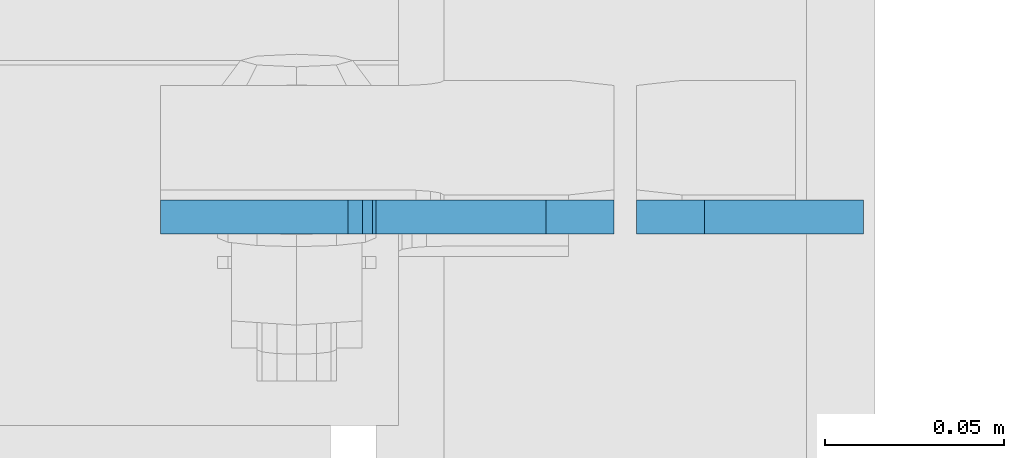
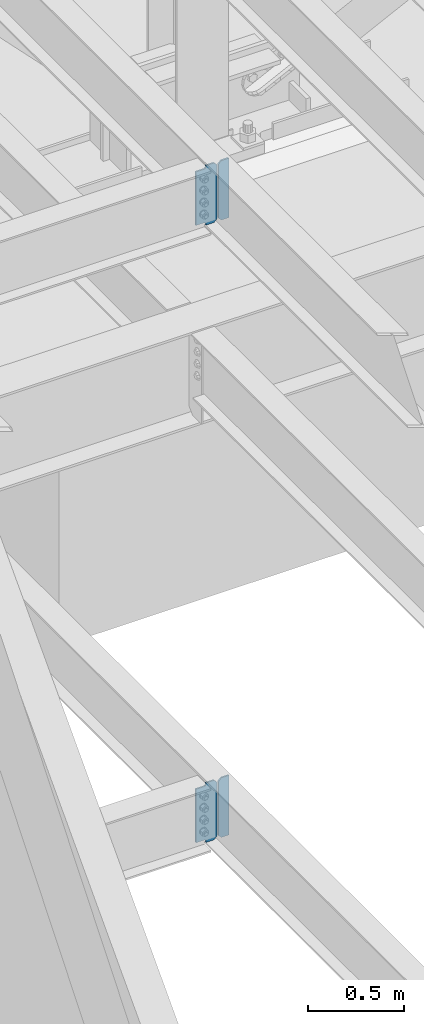
# One storey, part 1026 of 1179: 4 plates, 2 elements without a shape of their own.
"""IFC2X3 building model written with IfcOpenShell, lengths in millimetres."""

from ifc_helpers import new_model, si_unit, frame, origin_with_axes, place, context, subcontext, project, spatial, faceted_brep, material, type_object, element, aggregate, save


model = new_model("IFC2X3")

# Units and contexts
model_context = context("Model", 3, precision=1e-05, world=origin_with_axes())
body_context = subcontext(model_context, "Body", "Model", "MODEL_VIEW")
ifc_project = project(units=[si_unit("LENGTHUNIT", "METRE", prefix="MILLI"), si_unit("AREAUNIT", "SQUARE_METRE"), si_unit("VOLUMEUNIT", "CUBIC_METRE"), si_unit("MASSUNIT", "GRAM", prefix="KILO"), si_unit("TIMEUNIT", "SECOND"), si_unit("PLANEANGLEUNIT", "RADIAN"), si_unit("SOLIDANGLEUNIT", "STERADIAN"), si_unit("THERMODYNAMICTEMPERATUREUNIT", "DEGREE_CELSIUS"), si_unit("LUMINOUSINTENSITYUNIT", "LUMEN")], contexts=[model_context])

# Site, building, storey
site_placement = place(None, origin_with_axes())
site = spatial("IfcSite", under=ifc_project, at=site_placement, CompositionType="ELEMENT")
building_placement = place(site_placement, origin_with_axes())
building = spatial("IfcBuilding", under=site, at=building_placement, Name="Undefined", CompositionType="ELEMENT")
storey_placement = place(building_placement, origin_with_axes())
storey = spatial("IfcBuildingStorey", under=building, at=storey_placement, Name="Undefined", CompositionType="ELEMENT", Elevation=0.0)

# Assembly, plate
assembly_1_placement = place(storey_placement, origin_with_axes())
assembly_1 = element("IfcElementAssembly", 1, at=assembly_1_placement, inside=storey, Name="BEAM", AssemblyPlace="NOTDEFINED", PredefinedType="RIGID_FRAME")
ifc_material = material(Name="STEEL/A36")
plate_type_1 = type_object("IfcPlateType", PredefinedType="NOTDEFINED")
plate_1_placement = place(assembly_1_placement, frame((2409.825, 30729.2379999161, 7623.175), z_axis=(0.0, 0.0, 1.0), x_axis=(-1.0, 0.0, 0.0)))
plate_1 = element("IfcPlate", 2, at=plate_1_placement, type_object=plate_type_1, material=ifc_material, Name="PLATE", context=body_context, shape_type="Brep", body=[
    faceted_brep([(66.6749997905281, -4.76249999999709, 0.0), (66.6749997905281, 4.76249999999709, 0.0), (66.6750000714383, 4.76250000000073, 6.3500003080926), (66.6750000714383, -4.76250000000073, 6.3500003080926), (67.6417300265421, 4.76250000000073, 11.2100797903313), (67.6417300265421, -4.76250000000073, 11.2100797903313), (70.3947439338372, 4.76250000000073, 15.3302562193203), (70.3947439338372, -4.76250000000073, 15.3302562193203), (74.5149203869441, 4.76250000000073, 18.0832700905248), (74.5149203869441, -4.76250000000073, 18.0832700905248), (79.3749998776511, 4.76250000000073, 19.0500000030534), (79.3749998776511, -4.76250000000073, 19.0500000030534), (127.000004868059, -4.76250000000073, 19.0500000145084), (127.000004873054, 4.76250000000073, 19.0500000145084), (19.0499992370605, -4.76250000000073, 0.0), (0.0, -4.76250000000073, 19.0499992370605), (0.0, 4.76250000000073, 19.0499992370605), (19.0499992370605, 4.76250000000073, 0.0), (0.0, -4.76249999999709, 358.775000762939), (0.0, 4.76249999999709, 358.775000762939), (19.0499992370605, -4.76249999999709, 377.825), (19.0499992370605, 4.76249999999709, 377.825), (66.6749998164378, -4.76249999999709, 377.825), (66.6749998164378, 4.76249999999709, 377.825), (66.6749999434469, -4.76249999999709, 371.474999553748), (66.6749999434469, 4.76249999999709, 371.474999553748), (67.641729938794, -4.76249999999709, 366.614920114053), (67.641729938794, 4.76249999999709, 366.614920114053), (70.394743855788, -4.76249999999709, 362.494743732281), (70.394743855788, 4.76249999999709, 362.494743732281), (74.5149202922948, -4.76249999999709, 359.741729897201), (74.5149202922948, 4.76249999999709, 359.741729897201), (79.3749997512095, -4.76249999999709, 358.774999998475), (79.3749997512095, 4.76249999999709, 358.774999998475), (127.000000004868, -4.76249999999709, 358.774999992755), (127.0, 4.76249999999709, 358.774999992755)], [[[0, 1, 2, 3]], [[3, 2, 4, 5]], [[5, 4, 6, 7]], [[7, 6, 8, 9]], [[9, 8, 10, 11]], [[12, 11, 10, 13]], [[14, 15, 16, 17]], [[15, 18, 19, 16]], [[18, 20, 21, 19]], [[21, 20, 22, 23]], [[22, 24, 25, 23]], [[26, 27, 25, 24]], [[28, 29, 27, 26]], [[30, 31, 29, 28]], [[32, 33, 31, 30]], [[34, 35, 33, 32]], [[35, 34, 12, 13]], [[8, 6, 4, 2, 1, 17, 16, 19, 21, 23, 25, 27, 29, 31, 33, 35, 13, 10]], [[14, 17, 1, 0]], [[34, 32, 30, 28, 26, 24, 22, 20, 18, 15, 14, 0, 3, 5, 7, 9, 11, 12]]]),
])

assembly_2_placement = place(storey_placement, origin_with_axes())
assembly_2 = element("IfcElementAssembly", 3, at=assembly_2_placement, inside=storey, Name="BEAM", AssemblyPlace="NOTDEFINED", PredefinedType="RIGID_FRAME")
plate_2_placement = place(assembly_2_placement, frame((2409.82485351563, 30729.2379999289, 3711.575), z_axis=(0.0, 0.0, 1.0), x_axis=(-1.0, 0.0, 0.0)))
plate_2 = element("IfcPlate", 4, at=plate_2_placement, type_object=plate_type_1, material=ifc_material, Name="PLATE", context=body_context, shape_type="Brep", body=[
    faceted_brep([(66.6760135000841, -4.76250000000073, 0.0), (66.6760161004204, 4.76250000000073, 0.0), (66.6760161004204, 4.76250000000073, 6.35000095367513), (66.6760135000841, -4.76250000000073, 6.35000095367513), (67.6427460230079, 4.76250000000073, 11.2100804717206), (67.6427434226716, -4.76250000000073, 11.2100804717206), (70.3957599234891, 4.76250000000073, 15.3302569398738), (70.3957573231492, -4.76250000000073, 15.3302569398738), (74.5159363916428, 4.76250000000073, 18.0832708403518), (74.5159337913065, -4.76250000000073, 18.0832708403518), (79.3760159096855, 4.76250000000073, 19.0500007629394), (79.3760133093492, -4.76250000000073, 19.0500007629394), (127.000004868059, -4.76250000000073, 19.0500000145084), (127.000004873054, 4.76250000000073, 19.0500000145084), (19.0499992370605, -4.76250000000073, 0.0), (0.0, -4.76250000000073, 19.0499992370605), (0.0, 4.76250000000073, 19.0499992370605), (19.0499992370605, 4.76250000000073, 0.0), (0.0, -4.76249999999709, 358.775000762939), (0.0, 4.76249999999709, 358.775000762939), (19.0499992370605, -4.76249999999709, 377.825), (19.0499992370605, 4.76249999999709, 377.825), (66.676020440379, -4.76250000000073, 377.825), (66.6760230406981, 4.76250000000073, 377.825), (66.676020440374, -4.76250000000073, 371.474999046325), (66.6760230406976, 4.76250000000073, 371.474999046325), (67.642750362962, -4.76250000000073, 366.614919528279), (67.6427529632856, 4.76250000000073, 366.614919528279), (70.3957642634405, -4.76250000000073, 362.494743060126), (70.395766863764, 4.76250000000073, 362.494743060126), (74.5159407315941, -4.76250000000073, 359.741729159648), (74.5159433319177, 4.76250000000073, 359.741729159648), (79.3760202496401, -4.76250000000073, 358.77499923706), (79.3760228499636, 4.76250000000073, 358.77499923706), (127.000000004868, -4.76249999999709, 358.774999992755), (127.0, 4.76249999999709, 358.774999992755)], [[[0, 1, 2, 3]], [[3, 2, 4, 5]], [[5, 4, 6, 7]], [[7, 6, 8, 9]], [[9, 8, 10, 11]], [[12, 11, 10, 13]], [[14, 15, 16, 17]], [[15, 18, 19, 16]], [[18, 20, 21, 19]], [[21, 20, 22, 23]], [[22, 24, 25, 23]], [[26, 27, 25, 24]], [[28, 29, 27, 26]], [[30, 31, 29, 28]], [[32, 33, 31, 30]], [[34, 35, 33, 32]], [[35, 34, 12, 13]], [[8, 6, 4, 2, 1, 17, 16, 19, 21, 23, 25, 27, 29, 31, 33, 35, 13, 10]], [[14, 17, 1, 0]], [[34, 32, 30, 28, 26, 24, 22, 20, 18, 15, 14, 0, 3, 5, 7, 9, 11, 12]]]),
])

# Plate
plate_type_2 = type_object("IfcPlateType", PredefinedType="NOTDEFINED")
plate_3_placement = place(assembly_1_placement, frame((2416.175, 30729.2379999161, 7623.175), z_axis=(0.0, 0.0, 1.0), x_axis=(1.0, 0.0, 0.0)))
plate_3 = element("IfcPlate", 5, at=plate_3_placement, type_object=plate_type_2, material=ifc_material, Name="PLATE", context=body_context, shape_type="Brep", body=[
    faceted_brep([(0.0, -4.76250000000073, 19.0499992370605), (0.0, -4.76249999999709, 358.775000762939), (0.0, 4.76249999999709, 358.775000762939), (0.0, 4.76250000000073, 19.0499992370605), (19.0499992370605, -4.76249999999709, 377.825), (19.0499992370605, 4.76249999999709, 377.825), (63.5, -4.76250000000073, 377.825012207031), (63.5, 4.76250000000073, 377.825012207031), (63.5, -4.76250000000073, 0.0), (63.5, 4.76250000000073, 0.0), (19.0499992370605, -4.76250000000073, 0.0), (19.0499992370605, 4.76250000000073, 0.0)], [[[0, 1, 2, 3]], [[1, 4, 5, 2]], [[4, 6, 7, 5]], [[6, 8, 9, 7]], [[8, 10, 11, 9]], [[10, 0, 3, 11]], [[5, 7, 9, 11, 3, 2]], [[10, 8, 6, 4, 1, 0]]]),
])

aggregate(assembly_1, [plate_3, plate_1])

plate_4_placement = place(assembly_2_placement, frame((2416.17485351563, 30729.2379999289, 3711.575), z_axis=(0.0, 0.0, 1.0), x_axis=(1.0, 0.0, 0.0)))
plate_4 = element("IfcPlate", 6, at=plate_4_placement, type_object=plate_type_2, material=ifc_material, Name="PLATE", context=body_context, shape_type="Brep", body=[
    faceted_brep([(0.0, -4.76250000000073, 19.0499992370605), (0.0, -4.76249999999709, 358.775000762939), (0.0, 4.76249999999709, 358.775000762939), (0.0, 4.76250000000073, 19.0499992370605), (19.0499992370605, -4.76249999999709, 377.825), (19.0499992370605, 4.76249999999709, 377.825), (63.5, -4.76250000000073, 377.825012207031), (63.5, 4.76250000000073, 377.825012207031), (63.5, -4.76250000000073, 0.0), (63.5, 4.76250000000073, 0.0), (19.0499992370605, -4.76250000000073, 0.0), (19.0499992370605, 4.76250000000073, 0.0)], [[[0, 1, 2, 3]], [[1, 4, 5, 2]], [[4, 6, 7, 5]], [[6, 8, 9, 7]], [[8, 10, 11, 9]], [[10, 0, 3, 11]], [[5, 7, 9, 11, 3, 2]], [[10, 8, 6, 4, 1, 0]]]),
])

aggregate(assembly_2, [plate_4, plate_2])

save(model, "model.ifc")
